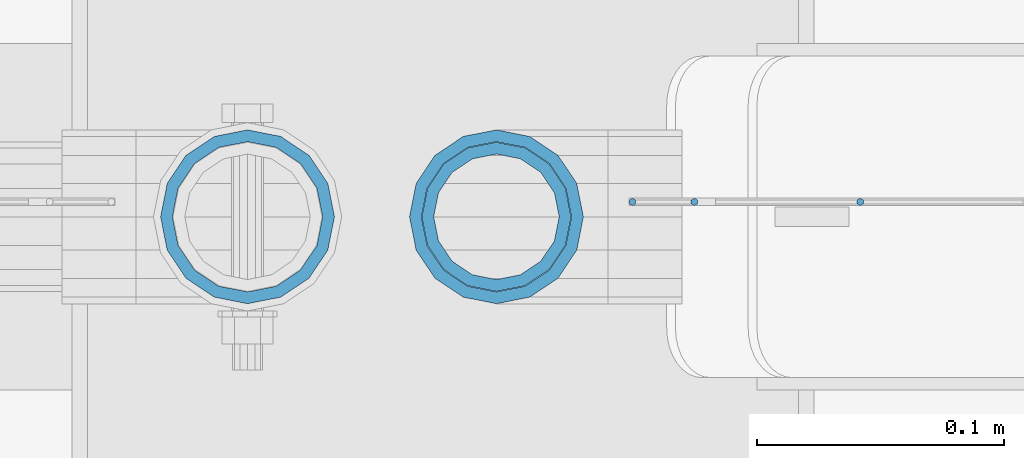
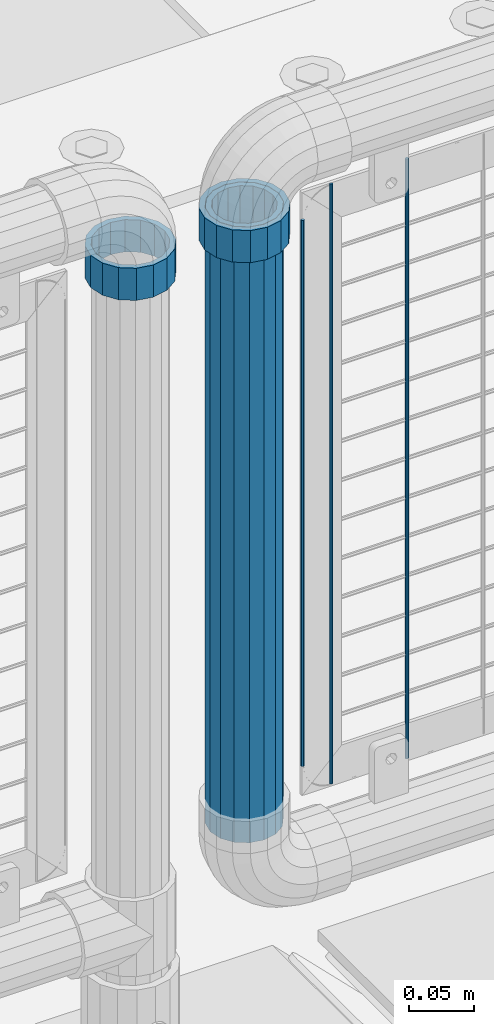
# One storey, part 87 of 208: 6 columns.
"""IFC2X3 building model written with IfcOpenShell, lengths in millimetres."""

from ifc_helpers import new_model, si_unit, frame, origin_with_axes, place, context, subcontext, project, spatial, faceted_brep, material, type_object, element, save


model = new_model("IFC2X3")

# Units and contexts
model_context = context("Model", 3, precision=1e-05, world=origin_with_axes())
body_context = subcontext(model_context, "Body", "Model", "MODEL_VIEW")
ifc_project = project(units=[si_unit("LENGTHUNIT", "METRE", prefix="MILLI"), si_unit("AREAUNIT", "SQUARE_METRE"), si_unit("VOLUMEUNIT", "CUBIC_METRE"), si_unit("MASSUNIT", "GRAM", prefix="KILO"), si_unit("TIMEUNIT", "SECOND"), si_unit("PLANEANGLEUNIT", "RADIAN"), si_unit("SOLIDANGLEUNIT", "STERADIAN"), si_unit("THERMODYNAMICTEMPERATUREUNIT", "DEGREE_CELSIUS"), si_unit("LUMINOUSINTENSITYUNIT", "LUMEN")], contexts=[model_context])

# Site, building, storey
site_placement = place(None, origin_with_axes())
site = spatial("IfcSite", under=ifc_project, at=site_placement, CompositionType="ELEMENT")
building_placement = place(site_placement, origin_with_axes())
building = spatial("IfcBuilding", under=site, at=building_placement, Name="Standard", CompositionType="ELEMENT")
storey_placement = place(building_placement, origin_with_axes())
storey = spatial("IfcBuildingStorey", under=building, at=storey_placement, Name="Undefined", CompositionType="ELEMENT", Elevation=0.0)

# Columns
ifc_material_1 = material(Name="Misc_Undefined")
column_type_1 = type_object("IfcColumnType", PredefinedType="NOTDEFINED")
column_1_placement = place(storey_placement, frame((-27328.39, 4664.5, 894.849999999999), z_axis=(-1.0, 0.0, 0.0), x_axis=(0.0, 0.0, 1.0)))
element("IfcColumn", 1, at=column_1_placement, inside=storey, type_object=column_type_1, material=ifc_material_1, context=body_context, shape_type="Brep", body=[
    faceted_brep([(0.0, -30.3500000000004, 0.0), (0.0, -28.0397438117179, 11.6144421722784), (30.0, -28.0397438117179, 11.6144421722805), (30.0, -30.3500000000004, 0.0), (0.0, -21.4606908090118, 21.4606908090136), (30.0, -21.4606908090118, 21.4606908090117), (0.0, -11.6144421722802, 28.0397438117143), (30.0, -11.6144421722802, 28.0397438117175), (0.0, 0.0, 30.3499999999985), (30.0, 0.0, 30.35), (0.0, 11.6144421722802, 28.0397438117143), (30.0, 11.6144421722802, 28.0397438117175), (0.0, 21.4606908090118, 21.4606908090136), (30.0, 21.4606908090118, 21.4606908090117), (0.0, 28.0397438117179, 11.6144421722784), (30.0, 28.0397438117179, 11.6144421722805), (0.0, 30.3500000000004, 0.0), (30.0, 30.3500000000004, 0.0), (0.0, 28.0397438117179, -11.6144421722784), (30.0, 28.0397438117179, -11.6144421722805), (0.0, 21.4606908090118, -21.4606908090136), (30.0, 21.4606908090118, -21.4606908090117), (0.0, 11.6144421722802, -28.0397438117143), (30.0, 11.6144421722802, -28.0397438117175), (0.0, 0.0, -30.3499999999985), (30.0, 0.0, -30.35), (0.0, -11.6144421722802, -28.0397438117143), (30.0, -11.6144421722802, -28.0397438117175), (0.0, -21.4606908090118, -21.4606908090136), (30.0, -21.4606908090118, -21.4606908090117), (0.0, -28.0397438117179, -11.6144421722784), (30.0, -28.0397438117179, -11.6144421722805), (0.0, -35.1499999999996, 0.0), (0.0, -32.4743655677721, -13.4513226476338), (30.0, -32.4743655677721, -13.4513226476329), (30.0, -35.1499999999996, 0.0), (0.0, -24.8548033587067, -24.8548033587067), (30.0, -24.8548033587067, -24.8548033587072), (0.0, -13.4513226476329, -32.4743655677739), (30.0, -13.4513226476329, -32.4743655677717), (0.0, 0.0, -35.1499999999996), (30.0, 0.0, -35.15), (0.0, 13.4513226476329, -32.4743655677739), (30.0, 13.4513226476329, -32.4743655677717), (0.0, 24.8548033587067, -24.8548033587067), (30.0, 24.8548033587067, -24.8548033587072), (0.0, 32.4743655677721, -13.4513226476338), (30.0, 32.4743655677721, -13.4513226476329), (0.0, 35.1499999999996, 0.0), (30.0, 35.1499999999996, 0.0), (0.0, 32.4743655677721, 13.4513226476338), (30.0, 32.4743655677721, 13.4513226476329), (0.0, 24.8548033587067, 24.8548033587067), (30.0, 24.8548033587067, 24.8548033587072), (0.0, 13.4513226476329, 32.4743655677739), (30.0, 13.4513226476329, 32.4743655677717), (0.0, 0.0, 35.1499999999996), (30.0, 0.0, 35.15), (0.0, -13.4513226476329, 32.4743655677739), (30.0, -13.4513226476329, 32.4743655677717), (0.0, -24.8548033587067, 24.8548033587067), (30.0, -24.8548033587067, 24.8548033587072), (0.0, -32.4743655677721, 13.4513226476338), (30.0, -32.4743655677721, 13.4513226476329)], [[[0, 1, 2, 3]], [[1, 4, 5, 2]], [[4, 6, 7, 5]], [[6, 8, 9, 7]], [[8, 10, 11, 9]], [[10, 12, 13, 11]], [[12, 14, 15, 13]], [[14, 16, 17, 15]], [[16, 18, 19, 17]], [[18, 20, 21, 19]], [[20, 22, 23, 21]], [[22, 24, 25, 23]], [[24, 26, 27, 25]], [[26, 28, 29, 27]], [[28, 30, 31, 29]], [[30, 0, 3, 31]], [[32, 33, 34, 35]], [[33, 36, 37, 34]], [[36, 38, 39, 37]], [[38, 40, 41, 39]], [[40, 42, 43, 41]], [[42, 44, 45, 43]], [[44, 46, 47, 45]], [[46, 48, 49, 47]], [[48, 50, 51, 49]], [[50, 52, 53, 51]], [[52, 54, 55, 53]], [[54, 56, 57, 55]], [[56, 58, 59, 57]], [[58, 60, 61, 59]], [[60, 62, 63, 61]], [[62, 32, 35, 63]], [[37, 39, 41, 43, 45, 47, 49, 51, 53, 55, 57, 59, 61, 63, 35, 34], [5, 7, 9, 11, 13, 15, 17, 19, 21, 23, 25, 27, 29, 31, 3, 2]], [[62, 60, 58, 56, 54, 52, 50, 48, 46, 44, 42, 40, 38, 36, 33, 32], [30, 28, 26, 24, 22, 20, 18, 16, 14, 12, 10, 8, 6, 4, 1, 0]]]),
])
column_2_placement = place(storey_placement, frame((-27429.0, 4664.5, 894.85), z_axis=(1.0, 0.0, 0.0), x_axis=(0.0, 0.0, 1.0)))
element("IfcColumn", 2, at=column_2_placement, inside=storey, type_object=column_type_1, material=ifc_material_1, context=body_context, shape_type="Brep", body=[
    faceted_brep([(0.0, -30.3500000000004, 0.0), (0.0, -28.0397438117179, 11.6144421722784), (30.0, -28.0397438117179, 11.6144421722805), (30.0, -30.3500000000004, 0.0), (0.0, -21.4606908090118, 21.4606908090136), (30.0, -21.4606908090118, 21.4606908090117), (0.0, -11.6144421722802, 28.0397438117143), (30.0, -11.6144421722802, 28.0397438117175), (0.0, 0.0, 30.3499999999985), (30.0, 0.0, 30.35), (0.0, 11.6144421722802, 28.0397438117143), (30.0, 11.6144421722802, 28.0397438117175), (0.0, 21.4606908090118, 21.4606908090136), (30.0, 21.4606908090118, 21.4606908090117), (0.0, 28.0397438117179, 11.6144421722784), (30.0, 28.0397438117179, 11.6144421722805), (0.0, 30.3500000000004, 0.0), (30.0, 30.3500000000004, 0.0), (0.0, 28.0397438117179, -11.6144421722784), (30.0, 28.0397438117179, -11.6144421722805), (0.0, 21.4606908090118, -21.4606908090136), (30.0, 21.4606908090118, -21.4606908090117), (0.0, 11.6144421722802, -28.0397438117143), (30.0, 11.6144421722802, -28.0397438117175), (0.0, 0.0, -30.3499999999985), (30.0, 0.0, -30.35), (0.0, -11.6144421722802, -28.0397438117143), (30.0, -11.6144421722802, -28.0397438117175), (0.0, -21.4606908090118, -21.4606908090136), (30.0, -21.4606908090118, -21.4606908090117), (0.0, -28.0397438117179, -11.6144421722784), (30.0, -28.0397438117179, -11.6144421722805), (0.0, -35.1499999999996, 0.0), (0.0, -32.4743655677721, -13.4513226476338), (30.0, -32.4743655677721, -13.4513226476329), (30.0, -35.1499999999996, 0.0), (0.0, -24.8548033587067, -24.8548033587067), (30.0, -24.8548033587067, -24.8548033587072), (0.0, -13.4513226476329, -32.4743655677739), (30.0, -13.4513226476329, -32.4743655677717), (0.0, 0.0, -35.1499999999996), (30.0, 0.0, -35.15), (0.0, 13.4513226476329, -32.4743655677739), (30.0, 13.4513226476329, -32.4743655677717), (0.0, 24.8548033587067, -24.8548033587067), (30.0, 24.8548033587067, -24.8548033587072), (0.0, 32.4743655677721, -13.4513226476338), (30.0, 32.4743655677721, -13.4513226476329), (0.0, 35.1499999999996, 0.0), (30.0, 35.1499999999996, 0.0), (0.0, 32.4743655677721, 13.4513226476338), (30.0, 32.4743655677721, 13.4513226476329), (0.0, 24.8548033587067, 24.8548033587067), (30.0, 24.8548033587067, 24.8548033587072), (0.0, 13.4513226476329, 32.4743655677739), (30.0, 13.4513226476329, 32.4743655677717), (0.0, 0.0, 35.1499999999996), (30.0, 0.0, 35.15), (0.0, -13.4513226476329, 32.4743655677739), (30.0, -13.4513226476329, 32.4743655677717), (0.0, -24.8548033587067, 24.8548033587067), (30.0, -24.8548033587067, 24.8548033587072), (0.0, -32.4743655677721, 13.4513226476338), (30.0, -32.4743655677721, 13.4513226476329)], [[[0, 1, 2, 3]], [[1, 4, 5, 2]], [[4, 6, 7, 5]], [[6, 8, 9, 7]], [[8, 10, 11, 9]], [[10, 12, 13, 11]], [[12, 14, 15, 13]], [[14, 16, 17, 15]], [[16, 18, 19, 17]], [[18, 20, 21, 19]], [[20, 22, 23, 21]], [[22, 24, 25, 23]], [[24, 26, 27, 25]], [[26, 28, 29, 27]], [[28, 30, 31, 29]], [[30, 0, 3, 31]], [[32, 33, 34, 35]], [[33, 36, 37, 34]], [[36, 38, 39, 37]], [[38, 40, 41, 39]], [[40, 42, 43, 41]], [[42, 44, 45, 43]], [[44, 46, 47, 45]], [[46, 48, 49, 47]], [[48, 50, 51, 49]], [[50, 52, 53, 51]], [[52, 54, 55, 53]], [[54, 56, 57, 55]], [[56, 58, 59, 57]], [[58, 60, 61, 59]], [[60, 62, 63, 61]], [[62, 32, 35, 63]], [[37, 39, 41, 43, 45, 47, 49, 51, 53, 55, 57, 59, 61, 63, 35, 34], [5, 7, 9, 11, 13, 15, 17, 19, 21, 23, 25, 27, 29, 31, 3, 2]], [[62, 60, 58, 56, 54, 52, 50, 48, 46, 44, 42, 40, 38, 36, 33, 32], [30, 28, 26, 24, 22, 20, 18, 16, 14, 12, 10, 8, 6, 4, 1, 0]]]),
])
ifc_material_2 = material()
column_type_2 = type_object("IfcColumnType", PredefinedType="NOTDEFINED")
column_3_placement = place(storey_placement, frame((-27328.39, 4664.5, 349.86), z_axis=(-1.0, 0.0, 0.0), x_axis=(0.0, 0.0, 1.0)))
element("IfcColumn", 3, at=column_3_placement, inside=storey, type_object=column_type_2, material=ifc_material_2, context=body_context, shape_type="Brep", body=[
    faceted_brep([(0.0, -25.3500000000004, 0.0), (0.0, -23.4203461491616, 9.70102501045403), (574.992910334213, -23.4203461491616, 9.70102501045403), (574.990000024649, -25.3500000000004, 0.0), (0.0, -17.9251569030794, 17.9251569030785), (574.995377579387, -17.9251569030794, 17.9251569030785), (0.0, -9.70102501045494, 23.4203461491597), (574.997026144459, -9.70102501045494, 23.4203461491597), (0.0, 0.0, 25.3499999999985), (574.997605050341, 0.0, 25.3499999999985), (0.0, 9.70102501045494, 23.4203461491597), (574.997026163861, 9.70102501045494, 23.4203461491597), (0.0, 17.9251569030794, 17.9251569030785), (574.995377615237, 17.9251569030794, 17.9251569030785), (0.0, 23.4203461491616, 9.70102501045403), (574.992910381054, 23.4203461491616, 9.70102501045403), (0.0, 25.3500000000004, 0.0), (574.990000075349, 25.3500000000004, 0.0), (0.0, 23.4203461491616, -9.70102501045403), (574.987089765785, 23.4203461491616, -9.70102501045403), (0.0, 17.9251569030794, -17.9251569030785), (574.984622520612, 17.9251569030794, -17.9251569030785), (0.0, 9.70102501045494, -23.4203461491597), (574.982973955539, 9.70102501045494, -23.4203461491597), (0.0, 0.0, -25.3499999999985), (574.982395049657, 0.0, -25.3499999999985), (0.0, -9.70102501045494, -23.4203461491597), (574.982973936137, -9.70102501045494, -23.4203461491597), (0.0, -17.9251569030794, -17.9251569030785), (574.984622484761, -17.9251569030794, -17.9251569030785), (0.0, -23.4203461491616, -9.70102501045403), (574.987089718945, -23.4203461491616, -9.70102501045403), (0.0, -30.1499999999996, 0.0), (0.0, -27.8549679052148, -11.5379054858058), (574.986538650343, -27.8549679052148, -11.5379054858058), (574.990000019849, -30.1499999999996, 0.0), (0.0, -21.3192694527743, -21.3192694527752), (574.983604247556, -21.3192694527743, -21.3192694527752), (0.0, -11.5379054858076, -27.8549679052157), (574.981643547714, -11.5379054858076, -27.8549679052157), (0.0, 0.0, -30.1500000000015), (574.980955049592, 0.0, -30.1500000000015), (0.0, 11.5379054858076, -27.8549679052157), (574.98164357079, 11.5379054858076, -27.8549679052157), (0.0, 21.3192694527743, -21.3192694527752), (574.983604290195, 21.3192694527743, -21.3192694527752), (0.0, 27.8549679052157, -11.5379054858058), (574.986538706053, 27.8549679052157, -11.5379054858058), (0.0, 30.1499999999996, 0.0), (574.990000080149, 30.1499999999996, 0.0), (0.0, 27.8549679052157, 11.5379054858058), (574.993461449656, 27.8549679052157, 11.5379054858058), (0.0, 21.3192694527743, 21.3192694527752), (574.996395852442, 21.3192694527743, 21.3192694527752), (0.0, 11.5379054858076, 27.8549679052157), (574.998356552285, 11.5379054858076, 27.8549679052157), (0.0, 0.0, 30.1500000000015), (574.999045050406, 0.0, 30.1500000000015), (0.0, -11.5379054858076, 27.8549679052157), (574.998356529209, -11.5379054858076, 27.8549679052157), (0.0, -21.3192694527743, 21.3192694527752), (574.996395809804, -21.3192694527743, 21.3192694527752), (0.0, -27.8549679052157, 11.5379054858058), (574.993461393946, -27.8549679052157, 11.5379054858058)], [[[0, 1, 2, 3]], [[1, 4, 5, 2]], [[4, 6, 7, 5]], [[6, 8, 9, 7]], [[8, 10, 11, 9]], [[10, 12, 13, 11]], [[12, 14, 15, 13]], [[14, 16, 17, 15]], [[16, 18, 19, 17]], [[18, 20, 21, 19]], [[20, 22, 23, 21]], [[22, 24, 25, 23]], [[24, 26, 27, 25]], [[26, 28, 29, 27]], [[28, 30, 31, 29]], [[30, 0, 3, 31]], [[32, 33, 34, 35]], [[33, 36, 37, 34]], [[36, 38, 39, 37]], [[38, 40, 41, 39]], [[40, 42, 43, 41]], [[42, 44, 45, 43]], [[44, 46, 47, 45]], [[46, 48, 49, 47]], [[48, 50, 51, 49]], [[50, 52, 53, 51]], [[52, 54, 55, 53]], [[54, 56, 57, 55]], [[56, 58, 59, 57]], [[58, 60, 61, 59]], [[60, 62, 63, 61]], [[62, 32, 35, 63]], [[37, 39, 41, 43, 45, 47, 49, 51, 53, 55, 57, 59, 61, 63, 35, 34], [5, 7, 9, 11, 13, 15, 17, 19, 21, 23, 25, 27, 29, 31, 3, 2]], [[62, 60, 58, 56, 54, 52, 50, 48, 46, 44, 42, 40, 38, 36, 33, 32], [30, 28, 26, 24, 22, 20, 18, 16, 14, 12, 10, 8, 6, 4, 1, 0]]]),
])
column_type_3 = type_object("IfcColumnType", Name="D3", PredefinedType="NOTDEFINED")
column_4_placement = place(storey_placement, frame((-27181.362, 4670.4999688155, 353.02), z_axis=(-1.0, 0.0, 0.0), x_axis=(0.0, 0.0, 1.0)))
element("IfcColumn", 4, at=column_4_placement, inside=storey, type_object=column_type_3, material=ifc_material_1, ObjectType="D3", context=body_context, shape_type="Brep", body=[
    faceted_brep([(0.0, -1.49999999999909, 3.63797880709171e-12), (-7.27595761418343e-12, -0.749999999999091, -1.29903810567669), (560.0, -0.75, -1.29903810567703), (560.0, -1.5, 0.0), (-3.63797880709171e-12, 0.750000000000909, -1.29903810567669), (560.0, 0.75, -1.29903810567703), (0.0, 1.50000000000182, 3.63797880709171e-12), (560.0, 1.5, 0.0), (-3.63797880709171e-12, 0.750000000000909, 1.29903810567669), (560.0, 0.75, 1.29903810567703), (-7.27595761418343e-12, -0.749999999999091, 1.29903810567669), (560.0, -0.75, 1.29903810567703)], [[[0, 1, 2, 3]], [[1, 4, 5, 2]], [[4, 6, 7, 5]], [[6, 8, 9, 7]], [[8, 10, 11, 9]], [[10, 0, 3, 11]], [[5, 7, 9, 11, 3, 2]], [[10, 8, 6, 4, 1, 0]]]),
])
column_5_placement = place(storey_placement, frame((-27273.39, 4670.49998832922, 378.02), z_axis=(-1.0, 0.0, 0.0), x_axis=(0.0, 0.0, 1.0)))
element("IfcColumn", 5, at=column_5_placement, inside=storey, type_object=column_type_3, material=ifc_material_1, ObjectType="D3", context=body_context, shape_type="Brep", body=[
    faceted_brep([(0.0, -1.49999999999909, 3.63797880709171e-12), (-7.27595761418343e-12, -0.749999999999091, -1.29903810567669), (510.0, -0.75, -1.29903810567703), (510.0, -1.5, 0.0), (-3.63797880709171e-12, 0.750000000000909, -1.29903810567669), (510.0, 0.75, -1.29903810567703), (0.0, 1.50000000000182, 3.63797880709171e-12), (510.0, 1.5, 0.0), (-3.63797880709171e-12, 0.750000000000909, 1.29903810567669), (510.0, 0.75, 1.29903810567703), (-7.27595761418343e-12, -0.749999999999091, 1.29903810567669), (510.0, -0.75, 1.29903810567703)], [[[0, 1, 2, 3]], [[1, 4, 5, 2]], [[4, 6, 7, 5]], [[6, 8, 9, 7]], [[8, 10, 11, 9]], [[10, 0, 3, 11]], [[5, 7, 9, 11, 3, 2]], [[10, 8, 6, 4, 1, 0]]]),
])
column_6_placement = place(storey_placement, frame((-27248.39, 4670.49998302432, 353.02), z_axis=(-1.0, 0.0, 0.0), x_axis=(0.0, 0.0, 1.0)))
element("IfcColumn", 6, at=column_6_placement, inside=storey, type_object=column_type_3, material=ifc_material_1, ObjectType="D3", context=body_context, shape_type="Brep", body=[
    faceted_brep([(0.0, -1.49999999999909, 3.63797880709171e-12), (-7.27595761418343e-12, -0.749999999999091, -1.29903810567669), (560.0, -0.75, -1.29903810567703), (560.0, -1.5, 0.0), (-3.63797880709171e-12, 0.750000000000909, -1.29903810567669), (560.0, 0.75, -1.29903810567703), (0.0, 1.50000000000182, 3.63797880709171e-12), (560.0, 1.5, 0.0), (-3.63797880709171e-12, 0.750000000000909, 1.29903810567669), (560.0, 0.75, 1.29903810567703), (-7.27595761418343e-12, -0.749999999999091, 1.29903810567669), (560.0, -0.75, 1.29903810567703)], [[[0, 1, 2, 3]], [[1, 4, 5, 2]], [[4, 6, 7, 5]], [[6, 8, 9, 7]], [[8, 10, 11, 9]], [[10, 0, 3, 11]], [[5, 7, 9, 11, 3, 2]], [[10, 8, 6, 4, 1, 0]]]),
])

save(model, "model.ifc")
